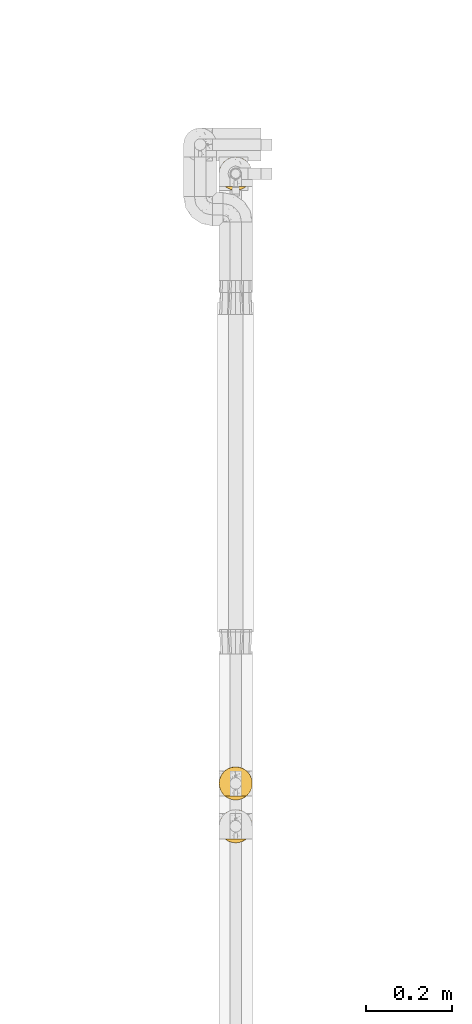
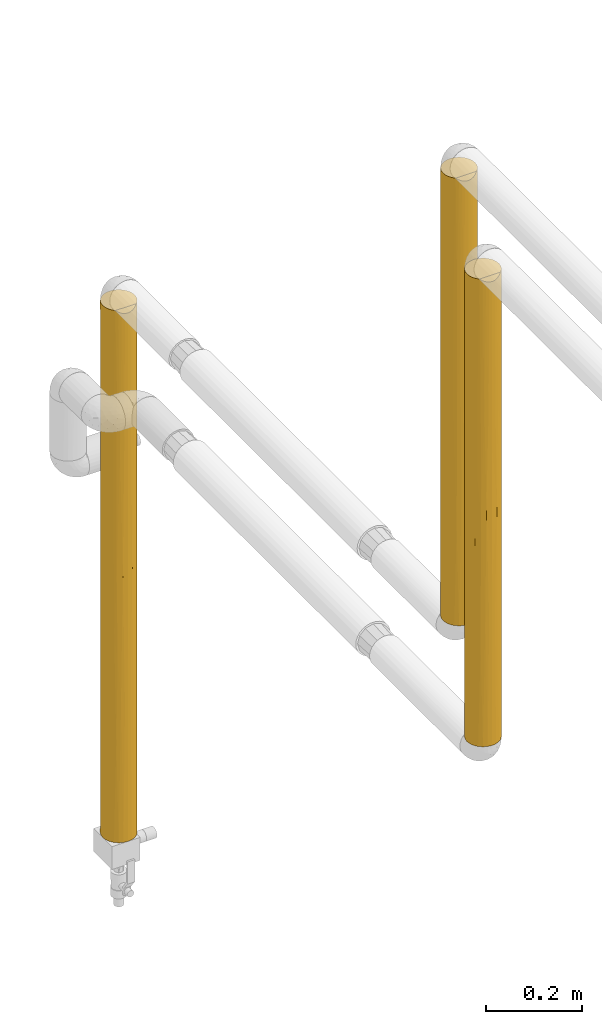
# One storey, part 33 of 827: 3 coverings.
"""IFC2X3 building model written with IfcOpenShell, lengths in millimetres."""

import ifcopenshell
import ifcopenshell.guid

model = None  # the IFC model being written
_history = None  # IfcOwnerHistory: only IFC2X3 demands one
_inside = {}  # id of a spatial element -> (the spatial element, [elements in it])
_under = {}  # id of a project, library or spatial element -> (it, [spatial elements below it])
_declared = {}  # id of a project -> (the project, [libraries it declares])
_typed = {}  # id of a type object -> (the type object, [elements of that type])
_made_of = {}  # id of a material, layer set ... -> (it, [elements and type objects made of it])


def new_model(schema):
    """Start an empty IFC model of exactly this schema.

    Asked for "IFC4X3", IfcOpenShell would pick the latest addendum, in which some entities
    have other attributes; the version numbers below select the first issue.
    IFC2X3 requires an IfcOwnerHistory on every rooted entity: one is made here for all.
    """
    global model, _history
    if schema == "IFC4X3":
        model = ifcopenshell.file(schema_version=(4, 3, 0, 0))
    else:
        model = ifcopenshell.file(schema=schema)
    _inside.clear()
    _under.clear()
    _declared.clear()
    _typed.clear()
    _made_of.clear()
    _history = None
    if model.schema == "IFC2X3":
        org = make("IfcOrganization", Name="unknown")
        user = make(
            "IfcPersonAndOrganization",
            ThePerson=make("IfcPerson", FamilyName="unknown"),
            TheOrganization=org,
        )
        app = make(
            "IfcApplication",
            ApplicationDeveloper=org,
            Version="unknown",
            ApplicationFullName="unknown",
            ApplicationIdentifier="unknown",
        )
        _history = make(
            "IfcOwnerHistory",
            OwningUser=user,
            OwningApplication=app,
            ChangeAction="ADDED",
            CreationDate=0,
        )
    return model


def make(cls, **values):
    """One entity of the class cls with the attributes given. An attribute that is None is left unset."""
    return model.create_entity(
        cls, **{name: value for name, value in values.items() if value is not None}
    )


def entity(cls, *values):
    """Any entity or typed value of the class cls, its attributes in the order of the schema. None: left unset."""
    e = model.create_entity(cls)
    for i, value in enumerate(values):
        if value is not None:
            e[i] = value
    return e


def rooted(cls, **values):
    """An entity with a GlobalId (a new one), such as an element, a storey or a relation."""
    return make(cls, GlobalId=ifcopenshell.guid.new(), OwnerHistory=_history, **values)


def si_unit(unit_type, name, prefix=None):
    """IfcSIUnit, for example si_unit("LENGTHUNIT", "METRE", prefix="MILLI")."""
    return make("IfcSIUnit", UnitType=unit_type, Prefix=prefix, Name=name)


def converted_unit(unit_type, name, factor, base, dimensions=None, offset=None):
    """IfcConversionBasedUnit, such as the inch: factor (a typed value) times the base unit."""
    return make(
        "IfcConversionBasedUnit"
        if offset is None
        else "IfcConversionBasedUnitWithOffset",
        ConversionOffset=offset,
        Dimensions=None
        if dimensions is None
        else entity("IfcDimensionalExponents", *dimensions),
        UnitType=unit_type,
        Name=name,
        ConversionFactor=make(
            "IfcMeasureWithUnit", ValueComponent=factor, UnitComponent=base
        ),
    )


def derived_unit(unit_type, elements):
    """IfcDerivedUnit: a product of units, each with its exponent."""
    return make(
        "IfcDerivedUnit",
        Elements=[
            make("IfcDerivedUnitElement", Unit=unit, Exponent=power)
            for unit, power in elements
        ],
        UnitType=unit_type,
    )


def assignment(units):
    """IfcUnitAssignment: the units of a project."""
    return None if units is None else make("IfcUnitAssignment", Units=units)


def point(xyz):
    """IfcCartesianPoint."""
    return None if xyz is None else make("IfcCartesianPoint", Coordinates=xyz)


def direction(xyz):
    """IfcDirection."""
    return None if xyz is None else make("IfcDirection", DirectionRatios=xyz)


def frame(location, z_axis=None, x_axis=None):
    """IfcAxis2Placement3D, a coordinate frame: its origin and axes. An axis left out is left unset."""
    return make(
        "IfcAxis2Placement3D",
        Location=point(location),
        Axis=direction(z_axis),
        RefDirection=direction(x_axis),
    )


def origin():
    """The frame at (0, 0, 0) with its axes left unset."""
    return frame((0.0, 0.0, 0.0))


def place(relative_to, where):
    """IfcLocalPlacement: puts the frame where relative to a parent placement (None: the world)."""
    return make(
        "IfcLocalPlacement", PlacementRelTo=relative_to, RelativePlacement=where
    )


def context(
    kind, dimensions, precision=None, world=None, true_north=None, identifier=None
):
    """IfcGeometricRepresentationContext, for example the 3D "Model" context."""
    return make(
        "IfcGeometricRepresentationContext",
        ContextIdentifier=identifier,
        ContextType=kind,
        CoordinateSpaceDimension=dimensions,
        Precision=precision,
        WorldCoordinateSystem=world,
        TrueNorth=true_north,
    )


def subcontext(parent, identifier, kind, view, scale=None):
    """IfcGeometricRepresentationSubContext, for example "Body" below "Model"."""
    return make(
        "IfcGeometricRepresentationSubContext",
        ContextIdentifier=identifier,
        ContextType=kind,
        ParentContext=parent,
        TargetScale=scale,
        TargetView=view,
    )


def project(units=None, contexts=None):
    """IfcProject with its units and contexts."""
    return rooted(
        "IfcProject",
        Name="project",
        RepresentationContexts=contexts,
        UnitsInContext=assignment(units),
    )


def spatial(cls, under=None, at=None, **own):
    """A site, building, storey or space (cls), placed at a placement, below another one or the project."""
    s = rooted(cls, ObjectPlacement=at, **own)
    if under is not None:
        _under.setdefault(under.id(), (under, []))[1].append(s)
    return s


def faces_of(points, faces, orient=None, outer=None):
    """IfcFace entities. A face is a list of loops; a loop is a list of indices into points, from 0.

    orient and outer hold one flag for each loop. By default every Orientation is true, the
    first loop of a face is its IfcFaceOuterBound and the others are IfcFaceBound.
    """
    made = []
    for i, loops in enumerate(faces):
        bounds = []
        for j, loop in enumerate(loops):
            is_outer = j == 0 if outer is None else outer[i][j]
            bounds.append(
                make(
                    "IfcFaceOuterBound" if is_outer else "IfcFaceBound",
                    Bound=make("IfcPolyLoop", Polygon=[points[k] for k in loop]),
                    Orientation=True if orient is None else orient[i][j],
                )
            )
        made.append(make("IfcFace", Bounds=bounds))
    return made


def faceted_brep(points, faces, orient=None, outer=None, voids=None):
    """IfcFacetedBrep: a solid bounded by flat faces; with voids (closed shells), ...WithVoids."""
    shared = [point(p) for p in points]
    hull = make("IfcClosedShell", CfsFaces=faces_of(shared, faces, orient, outer))
    if voids is None:
        return make("IfcFacetedBrep", Outer=hull)
    return make(
        "IfcFacetedBrepWithVoids",
        Outer=hull,
        Voids=[
            make(cls, CfsFaces=faces_of(shared, fs, o, b)) for cls, fs, o, b in voids
        ],
    )


def shape(context_of_items, identifier, shape_type, items):
    """IfcShapeRepresentation: the items that make up one representation, for example the "Body"."""
    return make(
        "IfcShapeRepresentation",
        ContextOfItems=context_of_items,
        RepresentationIdentifier=identifier,
        RepresentationType=shape_type,
        Items=items,
    )


def made_of(thing, what):
    """Note that an element or type object is made of a material, layer set ...; save() writes the relation."""
    if what is not None:
        _made_of.setdefault(what.id(), (what, []))[1].append(thing)
    return thing


def element(
    cls,
    number,
    at=None,
    inside=None,
    cuts=None,
    type_object=None,
    material=None,
    context=None,
    identifier="Body",
    shape_type=None,
    held_by="IfcProductDefinitionShape",
    body=None,
    shapes=None,
    **own,
):
    """One element of the class cls, such as IfcWall. Its Tag is "e" and its number.

    at: its placement. inside: the storey or other place that contains it. cuts: it is an
    opening in that element (IfcRelVoidsElement). A single representation is given by context,
    identifier, shape_type and body (its items); several are given by shapes. held_by: the class
    of the entity that holds the representations. save() writes the other relations.
    """
    e = rooted(cls, Tag="e%d" % number, ObjectPlacement=at, **own)
    if body is not None:
        shapes = [shape(context, identifier, shape_type, body)]
    if shapes is not None:
        e.Representation = make(held_by, Representations=shapes)
    if inside is not None:
        _inside.setdefault(inside.id(), (inside, []))[1].append(e)
    if cuts is not None:
        rooted(
            "IfcRelVoidsElement", RelatingBuildingElement=cuts, RelatedOpeningElement=e
        )
    if type_object is not None:
        _typed.setdefault(type_object.id(), (type_object, []))[1].append(e)
    return made_of(e, material)


def aggregate(whole, parts):
    """IfcRelAggregates: a whole, such as a stair, and the parts it consists of."""
    return rooted("IfcRelAggregates", RelatingObject=whole, RelatedObjects=parts)


def save(model, path):
    """Write the relations noted so far, then the file.

    IfcRelAggregates (storeys below a building ...), IfcRelContainedInSpatialStructure (elements
    in a storey), IfcRelDefinesByType, IfcRelAssociatesMaterial and IfcRelDeclares: one each for
    every whole, place, type object, material and project.
    """
    for whole, parts in _under.values():
        aggregate(whole, parts)
    for where, things in _inside.values():
        rooted(
            "IfcRelContainedInSpatialStructure",
            RelatedElements=things,
            RelatingStructure=where,
        )
    for kind, things in _typed.values():
        rooted("IfcRelDefinesByType", RelatedObjects=things, RelatingType=kind)
    for what, things in _made_of.values():
        rooted("IfcRelAssociatesMaterial", RelatedObjects=things, RelatingMaterial=what)
    for by, libraries in _declared.values():
        rooted("IfcRelDeclares", RelatingContext=by, RelatedDefinitions=libraries)
    model.write(path)


model = new_model("IFC2X3")

# Units and contexts
model_context = context("Model", 3, precision=0.01, world=origin(), true_north=direction((6.12303176911189e-17, 1.0)))
body_context = subcontext(model_context, "Body", "Model", "MODEL_VIEW")
ifc_project = project(units=[si_unit("LENGTHUNIT", "METRE", prefix="MILLI"), si_unit("AREAUNIT", "SQUARE_METRE"), si_unit("VOLUMEUNIT", "CUBIC_METRE"), converted_unit("PLANEANGLEUNIT", "DEGREE", entity("IfcRatioMeasure", 0.0174532925199433), si_unit("PLANEANGLEUNIT", "RADIAN"), dimensions=[0, 0, 0, 0, 0, 0, 0]), si_unit("MASSUNIT", "GRAM", prefix="KILO"), derived_unit("MASSDENSITYUNIT", [(si_unit("MASSUNIT", "GRAM", prefix="KILO"), 1), (si_unit("LENGTHUNIT", "METRE"), -3)]), derived_unit("MOMENTOFINERTIAUNIT", [(si_unit("LENGTHUNIT", "METRE"), 4)]), si_unit("TIMEUNIT", "SECOND"), si_unit("FREQUENCYUNIT", "HERTZ"), si_unit("THERMODYNAMICTEMPERATUREUNIT", "DEGREE_CELSIUS"), derived_unit("THERMALTRANSMITTANCEUNIT", [(si_unit("MASSUNIT", "GRAM", prefix="KILO"), 1), (si_unit("THERMODYNAMICTEMPERATUREUNIT", "KELVIN"), -1), (si_unit("TIMEUNIT", "SECOND"), -3)]), derived_unit("VOLUMETRICFLOWRATEUNIT", [(si_unit("LENGTHUNIT", "METRE"), 3), (si_unit("TIMEUNIT", "SECOND"), -1)]), derived_unit("MASSFLOWRATEUNIT", [(si_unit("MASSUNIT", "GRAM", prefix="KILO"), 1), (si_unit("TIMEUNIT", "SECOND"), -1)]), derived_unit("ROTATIONALFREQUENCYUNIT", [(si_unit("TIMEUNIT", "SECOND"), -1)]), si_unit("ELECTRICCURRENTUNIT", "AMPERE"), si_unit("ELECTRICVOLTAGEUNIT", "VOLT"), si_unit("POWERUNIT", "WATT"), si_unit("FORCEUNIT", "NEWTON", prefix="KILO"), si_unit("ILLUMINANCEUNIT", "LUX"), si_unit("LUMINOUSFLUXUNIT", "LUMEN"), si_unit("LUMINOUSINTENSITYUNIT", "CANDELA"), derived_unit("USERDEFINED", [(si_unit("MASSUNIT", "GRAM", prefix="KILO"), -1), (si_unit("LENGTHUNIT", "METRE"), -2), (si_unit("TIMEUNIT", "SECOND"), 3), (si_unit("LUMINOUSFLUXUNIT", "LUMEN"), 1)]), derived_unit("LINEARVELOCITYUNIT", [(si_unit("LENGTHUNIT", "METRE"), 1), (si_unit("TIMEUNIT", "SECOND"), -1)]), si_unit("PRESSUREUNIT", "PASCAL"), derived_unit("USERDEFINED", [(si_unit("LENGTHUNIT", "METRE"), -2), (si_unit("MASSUNIT", "GRAM", prefix="KILO"), 1), (si_unit("TIMEUNIT", "SECOND"), -2)]), derived_unit("LINEARFORCEUNIT", [(si_unit("MASSUNIT", "GRAM", prefix="KILO"), 1), (si_unit("LENGTHUNIT", "METRE"), 1), (si_unit("TIMEUNIT", "SECOND"), -2), (si_unit("LENGTHUNIT", "METRE"), -1)]), derived_unit("PLANARFORCEUNIT", [(si_unit("MASSUNIT", "GRAM", prefix="KILO"), 1), (si_unit("LENGTHUNIT", "METRE"), 1), (si_unit("TIMEUNIT", "SECOND"), -2), (si_unit("LENGTHUNIT", "METRE"), -2)])], contexts=[model_context])

# Site, building, storey
site_placement = place(None, origin())
site = spatial("IfcSite", under=ifc_project, at=site_placement, CompositionType="ELEMENT")
building_placement = place(site_placement, origin())
building = spatial("IfcBuilding", under=site, at=building_placement, CompositionType="ELEMENT")
storey_placement = place(building_placement, frame((0.0, 0.0, 28200.0)))
storey = spatial("IfcBuildingStorey", under=building, at=storey_placement, Name="08", CompositionType="ELEMENT", Elevation=28200.0)

# Coverings
covering_1_placement = place(storey_placement, frame((19736.27, 10367.59, 1832.08)))
element("IfcCovering", 1, at=covering_1_placement, inside=storey, Name=":ADSK_", ObjectType=":ADSK_", PredefinedType="INSULATION", context=body_context, shape_type="Brep", body=[
    faceted_brep([(74.9, 23.98, 1136.14), (77.51, 31.79, 1136.14), (78.4, 40.0, 1136.14), (77.09, 49.93, 1136.14), (73.25, 59.2, 1136.14), (67.15, 67.15, 1136.14), (59.2, 73.25, 1136.14), (49.93, 77.09, 1136.14), (40.0, 78.4, 1136.14), (30.06, 77.09, 1136.14), (20.8, 73.25, 1136.14), (12.84, 67.15, 1136.14), (6.74, 59.2, 1136.14), (2.9, 49.93, 1136.14), (1.6, 40.0, 1136.14), (2.48, 31.79, 1136.14), (5.09, 23.98, 1136.14), (9.31, 16.91, 1136.14), (14.94, 10.9, 1136.14), (65.05, 10.9, 1136.14), (70.68, 16.91, 1136.14), (78.4, 40.0, 1.6), (77.09, 30.06, 1.6), (73.25, 20.8, 1.6), (67.15, 12.84, 1.6), (59.2, 6.74, 1.6), (49.93, 2.9, 1.6), (40.0, 1.6, 1.6), (30.06, 2.9, 1.6), (20.8, 6.74, 1.6), (12.84, 12.84, 1.6), (6.74, 20.8, 1.6), (2.9, 30.06, 1.6), (1.6, 40.0, 1.6), (2.48, 48.2, 1.6), (5.09, 56.01, 1.6), (9.31, 63.08, 1.6), (14.94, 69.1, 1.6), (65.05, 69.1, 1.6), (70.68, 63.08, 1.6), (74.9, 56.01, 1.6), (77.51, 48.2, 1.6), (9.53, 16.62, 266.05), (4.52, 25.3, 349.66), (11.35, 14.42, 810.13), (17.3, 9.02, 565.81), (17.46, 8.9, 858.49), (1.6, 40.0, 434.34), (2.25, 32.94, 326.15), (2.58, 31.33, 568.87), (1.6, 40.0, 217.96), (11.22, 14.57, 572.59), (7.01, 20.33, 690.88), (3.58, 27.82, 865.89), (7.01, 20.33, 929.38), (1.6, 40.0, 703.4), (25.3, 4.52, 327.44), (29.12, 3.17, 560.44), (23.02, 5.55, 705.74), (40.0, 1.6, 910.47), (33.21, 2.2, 1127.44), (29.79, 2.98, 820.25), (26.63, 4.0, 1129.24), (40.0, 1.6, 694.09), (20.48, 6.92, 1132.17), (23.6, 5.27, 919.56), (40.0, 1.6, 1126.84), (40.0, 1.6, 434.34), (32.96, 2.24, 326.15), (40.0, 1.6, 217.97), (16.62, 9.53, 252.83), (1.6, 40.0, 919.78), (50.88, 3.17, 560.44), (68.64, 14.42, 810.13), (68.77, 14.57, 572.59), (72.98, 20.33, 690.88), (54.69, 4.52, 327.44), (63.37, 9.53, 252.83), (70.46, 16.62, 266.05), (47.03, 2.24, 326.15), (50.2, 2.98, 820.25), (53.36, 4.0, 1129.24), (46.78, 2.2, 1127.44), (75.47, 25.3, 349.66), (77.02, 29.82, 560.09), (56.97, 5.55, 705.74), (56.39, 5.27, 919.56), (62.53, 8.9, 858.49), (59.51, 6.92, 1132.17), (78.4, 40.0, 434.34), (77.74, 32.94, 326.15), (78.4, 40.0, 217.97), (78.4, 40.0, 919.77), (76.99, 29.72, 811.58), (78.4, 40.0, 703.39), (62.69, 9.02, 565.81), (72.98, 20.33, 929.38), (72.98, 59.66, 208.35), (76.41, 52.17, 271.85), (77.41, 48.66, 568.87), (72.98, 59.66, 446.86), (75.47, 54.69, 788.07), (59.51, 73.07, 5.57), (62.45, 71.15, 205.97), (68.36, 65.89, 502.0), (68.03, 66.24, 271.86), (70.46, 63.37, 871.68), (77.74, 47.05, 811.58), (56.64, 74.6, 317.56), (53.36, 76.0, 8.5), (46.78, 77.79, 10.29), (40.0, 78.4, 10.9), (40.0, 78.4, 227.27), (63.37, 70.46, 884.9), (47.11, 77.73, 811.58), (40.0, 78.4, 703.39), (40.0, 78.4, 919.77), (50.18, 77.02, 573.52), (48.63, 77.41, 257.08), (40.0, 78.4, 443.64), (54.69, 75.47, 856.69), (71.74, 61.61, 658.7), (62.69, 70.97, 571.93), (56.71, 74.57, 524.54), (11.96, 66.24, 271.86), (17.07, 70.8, 356.88), (33.21, 77.79, 10.29), (25.3, 75.47, 856.69), (9.53, 63.37, 871.68), (16.62, 70.46, 884.9), (20.48, 73.07, 5.57), (23.35, 74.6, 317.56), (26.63, 76.0, 8.5), (31.36, 77.41, 257.08), (23.28, 74.57, 524.54), (7.01, 59.66, 208.35), (4.52, 54.69, 788.07), (17.3, 70.97, 571.93), (3.58, 52.17, 271.85), (7.01, 59.66, 446.86), (29.81, 77.02, 573.52), (2.25, 47.05, 811.58), (2.58, 48.66, 568.87), (8.25, 61.61, 658.7), (32.88, 77.73, 811.58), (11.64, 65.89, 502.0)], [[[0, 1, 2, 3, 4, 5, 6, 7, 8, 9, 10, 11, 12, 13, 14, 15, 16, 17, 18, 19, 20]], [[21, 22, 23, 24, 25, 26, 27, 28, 29, 30, 31, 32, 33, 34, 35, 36, 37, 38, 39, 40, 41]], [[42, 43, 31]], [[44, 45, 46]], [[47, 48, 49]], [[32, 50, 33]], [[43, 42, 51]], [[52, 53, 49]], [[43, 32, 31]], [[50, 48, 47]], [[52, 54, 53]], [[53, 16, 15]], [[49, 53, 55]], [[54, 17, 16]], [[49, 55, 47]], [[54, 44, 17]], [[56, 57, 58]], [[18, 17, 44]], [[59, 60, 61]], [[45, 56, 58]], [[60, 62, 61]], [[63, 61, 57]], [[18, 46, 64]], [[58, 65, 46]], [[66, 60, 59]], [[67, 68, 69]], [[42, 30, 70]], [[30, 42, 31]], [[56, 29, 28]], [[51, 70, 45]], [[65, 64, 46]], [[28, 69, 68]], [[56, 68, 57]], [[52, 49, 43]], [[15, 71, 53]], [[30, 29, 70]], [[51, 45, 44]], [[53, 54, 16]], [[44, 54, 52]], [[44, 52, 51]], [[44, 46, 18]], [[29, 56, 70]], [[45, 70, 56]], [[43, 51, 52]], [[70, 51, 42]], [[28, 27, 69]], [[67, 63, 57]], [[28, 68, 56]], [[57, 68, 67]], [[57, 61, 58]], [[65, 58, 61]], [[46, 45, 58]], [[48, 32, 43]], [[32, 48, 50]], [[49, 48, 43]], [[61, 62, 65]], [[64, 65, 62]], [[61, 63, 59]], [[71, 15, 14]], [[71, 55, 53]], [[63, 67, 72]], [[73, 74, 75]], [[26, 25, 76]], [[77, 24, 78]], [[79, 72, 67]], [[80, 81, 82]], [[75, 83, 84]], [[83, 78, 23]], [[80, 85, 86]], [[25, 24, 77]], [[82, 59, 80]], [[87, 19, 88]], [[19, 87, 73]], [[89, 90, 91]], [[92, 93, 94]], [[84, 94, 93]], [[95, 74, 73]], [[0, 96, 93]], [[24, 23, 78]], [[92, 2, 1]], [[22, 83, 23]], [[72, 85, 80]], [[96, 0, 20]], [[22, 91, 90]], [[79, 26, 76]], [[88, 81, 86]], [[96, 73, 75]], [[0, 93, 1]], [[92, 1, 93]], [[83, 90, 84]], [[85, 72, 76]], [[26, 69, 27]], [[74, 83, 75]], [[77, 95, 76]], [[20, 19, 73]], [[93, 96, 75]], [[20, 73, 96]], [[95, 73, 87]], [[77, 78, 74]], [[76, 25, 77]], [[77, 74, 95]], [[83, 74, 78]], [[26, 79, 69]], [[67, 69, 79]], [[72, 79, 76]], [[85, 76, 95]], [[63, 72, 80]], [[95, 87, 85]], [[86, 85, 87]], [[22, 21, 91]], [[89, 94, 84]], [[22, 90, 83]], [[84, 90, 89]], [[75, 84, 93]], [[88, 86, 87]], [[81, 80, 86]], [[59, 82, 66]], [[59, 63, 80]], [[97, 98, 40]], [[99, 100, 101]], [[101, 4, 3]], [[38, 102, 103]], [[104, 100, 105]], [[105, 39, 38]], [[97, 40, 39]], [[41, 98, 91]], [[40, 98, 41]], [[5, 4, 106]], [[3, 92, 107]], [[99, 107, 94]], [[97, 105, 100]], [[99, 89, 98]], [[108, 102, 109]], [[101, 106, 4]], [[110, 111, 112]], [[6, 5, 113]], [[114, 115, 116]], [[117, 118, 119]], [[119, 115, 117]], [[7, 6, 120]], [[100, 104, 121]], [[110, 112, 118]], [[105, 103, 122]], [[122, 123, 120]], [[94, 107, 92]], [[103, 102, 108]], [[99, 94, 89]], [[109, 110, 118]], [[8, 7, 116]], [[123, 108, 117]], [[117, 108, 118]], [[5, 106, 113]], [[117, 115, 114]], [[21, 41, 91]], [[100, 99, 98]], [[121, 101, 100]], [[113, 122, 120]], [[105, 97, 39]], [[98, 97, 100]], [[122, 113, 106]], [[120, 6, 113]], [[114, 7, 120]], [[7, 114, 116]], [[117, 114, 120]], [[3, 2, 92]], [[99, 101, 107]], [[3, 107, 101]], [[118, 112, 119]], [[109, 118, 108]], [[122, 103, 108]], [[38, 103, 105]], [[105, 122, 104]], [[106, 104, 122]], [[104, 106, 121]], [[101, 121, 106]], [[98, 89, 91]], [[120, 123, 117]], [[122, 108, 123]], [[37, 124, 125]], [[126, 112, 111]], [[127, 10, 9]], [[128, 11, 129]], [[130, 131, 132]], [[37, 125, 130]], [[112, 126, 133]], [[125, 134, 131]], [[36, 124, 37]], [[36, 135, 124]], [[112, 133, 119]], [[136, 13, 12]], [[11, 128, 12]], [[125, 137, 134]], [[138, 35, 34]], [[13, 71, 14]], [[135, 138, 139]], [[140, 115, 119]], [[55, 141, 142]], [[139, 138, 142]], [[133, 132, 131]], [[143, 136, 128]], [[119, 133, 140]], [[142, 138, 47]], [[128, 136, 12]], [[115, 144, 116]], [[140, 144, 115]], [[135, 36, 35]], [[139, 145, 124]], [[71, 141, 55]], [[142, 47, 55]], [[131, 134, 140]], [[137, 128, 129]], [[116, 144, 9]], [[127, 140, 134]], [[139, 142, 136]], [[34, 50, 138]], [[11, 10, 129]], [[128, 137, 145]], [[138, 135, 35]], [[124, 135, 139]], [[10, 127, 129]], [[137, 129, 127]], [[9, 8, 116]], [[140, 127, 144]], [[9, 144, 127]], [[141, 13, 136]], [[13, 141, 71]], [[142, 141, 136]], [[132, 133, 126]], [[140, 133, 131]], [[143, 145, 139]], [[125, 145, 137]], [[136, 143, 139]], [[128, 145, 143]], [[130, 125, 131]], [[145, 125, 124]], [[50, 34, 33]], [[50, 47, 138]], [[127, 134, 137]], [[64, 62, 60, 66, 82, 81, 88, 19, 18]], [[130, 132, 126, 111, 110, 109, 102, 38, 37]]]),
])
covering_2_placement = place(storey_placement, frame((19736.27, 11781.06, 426.5)))
element("IfcCovering", 2, at=covering_2_placement, inside=storey, Name=":ADSK_", ObjectType=":ADSK_", PredefinedType="INSULATION", context=body_context, shape_type="Brep", body=[
    faceted_brep([(77.51, 31.79, 1348.98), (78.4, 40.0, 1348.98), (77.09, 49.93, 1348.98), (73.25, 59.2, 1348.98), (67.15, 67.15, 1348.98), (59.2, 73.25, 1348.98), (49.93, 77.09, 1348.98), (40.0, 78.4, 1348.98), (30.06, 77.09, 1348.98), (20.8, 73.25, 1348.98), (12.84, 67.15, 1348.98), (6.74, 59.2, 1348.98), (2.9, 49.93, 1348.98), (1.6, 40.0, 1348.98), (2.48, 31.79, 1348.98), (5.09, 23.98, 1348.98), (9.31, 16.91, 1348.98), (14.94, 10.9, 1348.98), (65.05, 10.9, 1348.98), (70.68, 16.91, 1348.98), (74.9, 23.98, 1348.98), (73.25, 20.8, 0.0), (67.15, 12.84, 0.0), (59.2, 6.74, 0.0), (49.93, 2.9, 0.0), (40.0, 1.6, 0.0), (30.06, 2.9, 0.0), (20.8, 6.74, 0.0), (12.84, 12.84, 0.0), (6.74, 20.8, 0.0), (2.9, 30.06, 0.0), (1.6, 40.0, 0.0), (2.9, 49.93, 0.0), (6.74, 59.2, 0.0), (12.84, 67.15, 0.0), (20.8, 73.25, 0.0), (30.06, 77.09, 0.0), (40.0, 78.4, 0.0), (49.93, 77.09, 0.0), (59.2, 73.25, 0.0), (67.15, 67.15, 0.0), (73.25, 59.2, 0.0), (77.09, 49.93, 0.0), (78.4, 40.0, 0.0), (77.09, 30.06, 0.0), (53.36, 4.0, 1342.08), (46.78, 2.2, 1340.28), (48.18, 2.48, 1015.12), (70.46, 16.62, 283.44), (63.37, 9.53, 252.76), (46.87, 2.21, 345.28), (54.69, 4.52, 373.39), (67.93, 13.65, 819.56), (72.98, 20.33, 876.9), (68.03, 13.75, 1068.01), (63.19, 9.39, 946.76), (62.48, 8.86, 1158.16), (56.67, 5.4, 983.53), (77.76, 33.04, 349.93), (78.4, 40.0, 216.37), (78.4, 40.0, 483.49), (51.28, 3.29, 692.36), (40.0, 1.6, 1123.3), (40.0, 1.6, 906.93), (76.29, 27.47, 205.68), (59.51, 6.92, 1345.01), (60.98, 7.84, 458.27), (78.4, 40.0, 1132.6), (76.41, 27.82, 1068.02), (72.98, 20.33, 1133.02), (75.47, 25.3, 415.33), (71.23, 17.65, 586.2), (78.4, 40.0, 916.23), (77.11, 30.15, 737.21), (62.75, 9.06, 671.58), (77.82, 33.35, 554.99), (78.4, 40.0, 699.86), (40.0, 1.6, 1339.68), (40.0, 1.6, 690.56), (40.0, 1.6, 474.19), (74.92, 24.03, 628.47), (66.63, 12.33, 513.34), (40.0, 1.6, 216.37), (70.46, 63.37, 259.19), (63.37, 70.46, 324.27), (77.46, 48.4, 700.74), (77.72, 47.17, 1024.42), (75.47, 54.69, 965.07), (54.69, 75.47, 245.05), (77.78, 46.83, 349.93), (75.47, 54.69, 383.91), (40.0, 78.4, 216.37), (40.0, 78.4, 1132.6), (63.37, 70.46, 1071.25), (47.4, 77.67, 921.72), (50.22, 77.01, 1127.26), (54.69, 75.47, 952.15), (65.85, 68.39, 542.23), (54.69, 75.47, 529.72), (62.42, 71.17, 742.23), (47.28, 77.7, 324.56), (51.72, 76.56, 740.93), (46.88, 77.77, 561.65), (57.02, 74.42, 1150.09), (70.46, 63.37, 1096.79), (72.05, 61.15, 885.64), (70.46, 63.37, 674.49), (67.43, 66.87, 844.54), (74.76, 56.3, 705.57), (70.39, 63.46, 466.84), (40.0, 78.4, 432.75), (40.0, 78.4, 649.12), (40.0, 78.4, 699.86), (40.0, 78.4, 865.49), (40.0, 78.4, 916.23), (40.0, 78.4, 483.49), (16.62, 70.46, 259.19), (9.53, 63.37, 324.27), (31.59, 77.46, 700.74), (32.82, 77.72, 1024.42), (25.3, 75.47, 965.07), (4.52, 54.69, 245.05), (33.16, 77.78, 349.93), (25.3, 75.47, 383.91), (1.6, 40.0, 216.37), (1.6, 40.0, 1132.6), (9.53, 63.37, 1071.25), (2.32, 47.4, 921.72), (2.98, 50.22, 1127.26), (4.52, 54.69, 952.15), (11.6, 65.85, 542.23), (4.52, 54.69, 529.72), (8.83, 62.42, 742.23), (2.29, 47.28, 324.56), (3.43, 51.72, 740.93), (2.22, 46.88, 561.65), (5.58, 57.02, 1150.09), (16.62, 70.46, 1096.79), (18.85, 72.05, 885.64), (16.62, 70.46, 674.49), (13.13, 67.43, 844.54), (23.69, 74.76, 705.57), (16.53, 70.39, 466.84), (1.6, 40.0, 432.74), (1.6, 40.0, 649.12), (1.6, 40.0, 699.86), (1.6, 40.0, 865.49), (1.6, 40.0, 916.23), (1.6, 40.0, 483.48), (3.58, 27.82, 1068.02), (12.06, 13.65, 819.56), (11.96, 13.75, 1068.01), (7.01, 20.33, 876.9), (16.8, 9.39, 946.76), (33.12, 2.21, 345.28), (28.71, 3.29, 692.36), (4.52, 25.3, 415.33), (3.7, 27.47, 205.68), (9.53, 16.62, 283.44), (2.23, 33.04, 349.93), (31.81, 2.48, 1015.12), (23.32, 5.4, 983.53), (26.63, 4.0, 1342.08), (20.48, 6.92, 1345.01), (7.01, 20.33, 1133.02), (17.51, 8.86, 1158.16), (19.01, 7.84, 458.27), (17.24, 9.06, 671.58), (33.21, 2.2, 1340.28), (8.77, 17.65, 586.2), (25.3, 4.52, 373.39), (16.62, 9.53, 252.76), (2.17, 33.35, 554.99), (13.36, 12.33, 513.34), (2.88, 30.15, 737.21), (5.39, 23.35, 685.49)], [[[0, 1, 2, 3, 4, 5, 6, 7, 8, 9, 10, 11, 12, 13, 14, 15, 16, 17, 18, 19, 20]], [[21, 22, 23, 24, 25, 26, 27, 28, 29, 30, 31, 32, 33, 34, 35, 36, 37, 38, 39, 40, 41, 42, 43, 44]], [[45, 46, 47]], [[22, 48, 49]], [[50, 24, 51]], [[52, 53, 54]], [[23, 51, 24]], [[55, 56, 57]], [[58, 59, 60]], [[57, 47, 61]], [[21, 48, 22]], [[47, 62, 63]], [[23, 22, 49]], [[64, 48, 21]], [[45, 57, 65]], [[66, 61, 51]], [[62, 47, 46]], [[67, 0, 68]], [[64, 59, 58]], [[20, 68, 0]], [[18, 54, 19]], [[19, 54, 69]], [[70, 71, 48]], [[69, 20, 19]], [[52, 71, 53]], [[64, 44, 59]], [[72, 68, 73]], [[61, 74, 57]], [[56, 18, 65]], [[53, 68, 69]], [[55, 74, 52]], [[73, 75, 76]], [[73, 68, 53]], [[67, 1, 0]], [[46, 77, 62]], [[61, 47, 63]], [[47, 57, 45]], [[78, 79, 61, 63]], [[61, 79, 50]], [[80, 53, 71]], [[70, 58, 75]], [[70, 80, 71]], [[49, 66, 51]], [[52, 81, 71]], [[51, 23, 49]], [[44, 43, 59]], [[82, 50, 79]], [[82, 25, 24]], [[74, 66, 81]], [[24, 50, 82]], [[61, 50, 51]], [[75, 58, 60]], [[58, 70, 64]], [[48, 64, 70]], [[21, 44, 64]], [[76, 72, 73]], [[75, 73, 80]], [[75, 60, 76]], [[55, 52, 54]], [[52, 74, 81]], [[54, 18, 56]], [[74, 55, 57]], [[57, 56, 65]], [[54, 56, 55]], [[53, 69, 54]], [[20, 69, 68]], [[68, 72, 67]], [[49, 48, 81]], [[61, 66, 74]], [[49, 81, 66]], [[48, 71, 81]], [[75, 80, 70]], [[53, 80, 73]], [[83, 40, 84]], [[85, 72, 76, 60]], [[2, 67, 86]], [[2, 87, 3]], [[84, 39, 88]], [[89, 42, 90]], [[38, 37, 91]], [[6, 92, 7]], [[85, 87, 86]], [[5, 4, 93]], [[94, 95, 96]], [[41, 90, 42]], [[97, 98, 99]], [[88, 100, 98]], [[101, 98, 102]], [[72, 86, 67]], [[95, 6, 103]], [[104, 93, 4]], [[39, 38, 88]], [[39, 84, 40]], [[103, 96, 95]], [[96, 93, 99]], [[105, 106, 107]], [[105, 108, 106]], [[42, 59, 43]], [[2, 1, 67]], [[40, 83, 41]], [[98, 100, 102]], [[109, 90, 83]], [[4, 3, 104]], [[105, 107, 104]], [[99, 107, 97]], [[101, 99, 98]], [[84, 97, 109]], [[90, 41, 83]], [[3, 87, 104]], [[105, 104, 87]], [[91, 100, 38]], [[84, 88, 98]], [[100, 91, 110]], [[60, 59, 89]], [[94, 96, 101]], [[100, 110, 102]], [[38, 100, 88]], [[94, 111, 112, 113, 114, 92]], [[102, 111, 101]], [[99, 101, 96]], [[95, 92, 6]], [[92, 95, 94]], [[103, 6, 5]], [[5, 93, 103]], [[93, 96, 103]], [[111, 94, 101]], [[102, 110, 115, 111]], [[85, 86, 72]], [[2, 86, 87]], [[89, 85, 60]], [[90, 109, 108]], [[42, 89, 59]], [[85, 89, 90]], [[109, 97, 106]], [[98, 97, 84]], [[109, 106, 108]], [[84, 109, 83]], [[108, 87, 85]], [[106, 97, 107]], [[87, 108, 105]], [[90, 108, 85]], [[99, 93, 107]], [[104, 107, 93]], [[116, 34, 117]], [[118, 114, 113, 112, 111, 115]], [[8, 92, 119]], [[8, 120, 9]], [[117, 33, 121]], [[122, 36, 123]], [[32, 31, 124]], [[12, 125, 13]], [[118, 120, 119]], [[11, 10, 126]], [[127, 128, 129]], [[35, 123, 36]], [[130, 131, 132]], [[121, 133, 131]], [[134, 131, 135]], [[114, 119, 92]], [[128, 12, 136]], [[137, 126, 10]], [[33, 32, 121]], [[33, 117, 34]], [[136, 129, 128]], [[129, 126, 132]], [[138, 139, 140]], [[138, 141, 139]], [[36, 91, 37]], [[8, 7, 92]], [[34, 116, 35]], [[131, 133, 135]], [[142, 123, 116]], [[10, 9, 137]], [[138, 140, 137]], [[132, 140, 130]], [[134, 132, 131]], [[117, 130, 142]], [[123, 35, 116]], [[9, 120, 137]], [[138, 137, 120]], [[124, 133, 32]], [[117, 121, 131]], [[133, 124, 143]], [[122, 115, 110, 91]], [[127, 129, 134]], [[133, 143, 135]], [[32, 133, 121]], [[127, 144, 145, 146, 147, 125]], [[135, 144, 134]], [[132, 134, 129]], [[128, 125, 12]], [[125, 128, 127]], [[136, 12, 11]], [[11, 126, 136]], [[126, 129, 136]], [[144, 127, 134]], [[135, 143, 148, 144]], [[118, 119, 114]], [[8, 119, 120]], [[122, 118, 115]], [[123, 142, 141]], [[36, 122, 91]], [[118, 122, 123]], [[142, 130, 139]], [[131, 130, 117]], [[142, 139, 141]], [[117, 142, 116]], [[141, 120, 118]], [[139, 130, 140]], [[120, 141, 138]], [[123, 141, 118]], [[132, 126, 140]], [[137, 140, 126]], [[14, 125, 149]], [[150, 151, 152]], [[153, 151, 150]], [[26, 82, 154]], [[155, 79, 78, 63]], [[156, 157, 158]], [[156, 159, 157]], [[157, 159, 124]], [[160, 161, 155]], [[162, 163, 161]], [[31, 30, 124]], [[152, 151, 164]], [[151, 16, 164]], [[165, 163, 17]], [[149, 164, 15]], [[29, 28, 158]], [[166, 155, 167]], [[168, 160, 62]], [[62, 77, 168]], [[169, 156, 158]], [[154, 82, 79]], [[26, 170, 27]], [[153, 165, 151]], [[168, 162, 160]], [[17, 16, 151]], [[158, 28, 171]], [[148, 159, 172]], [[166, 167, 173]], [[174, 152, 149]], [[149, 15, 14]], [[79, 155, 154]], [[174, 149, 147]], [[160, 162, 161]], [[63, 62, 160]], [[161, 167, 155]], [[154, 155, 170]], [[155, 63, 160]], [[174, 145, 172]], [[175, 156, 169]], [[28, 27, 171]], [[169, 152, 175]], [[27, 170, 171]], [[166, 171, 170]], [[26, 25, 82]], [[159, 148, 143, 124]], [[173, 171, 166]], [[169, 173, 150]], [[155, 166, 170]], [[26, 154, 170]], [[157, 124, 30]], [[156, 175, 172]], [[30, 29, 157]], [[158, 157, 29]], [[156, 172, 159]], [[169, 150, 152]], [[174, 147, 146, 145]], [[172, 145, 144, 148]], [[153, 167, 161]], [[167, 153, 150]], [[165, 161, 163]], [[151, 165, 17]], [[161, 165, 153]], [[15, 164, 16]], [[152, 164, 149]], [[125, 14, 13]], [[125, 147, 149]], [[167, 150, 173]], [[169, 158, 173]], [[171, 173, 158]], [[152, 174, 175]], [[175, 174, 172]], [[163, 162, 168, 77, 46, 45, 65, 18, 17]]]),
])
covering_3_placement = place(storey_placement, frame((19736.27, 10268.25, 1585.67)))
element("IfcCovering", 3, at=covering_3_placement, inside=storey, Name=":ADSK_", ObjectType=":ADSK_", PredefinedType="INSULATION", context=body_context, shape_type="Brep", body=[
    faceted_brep([(77.51, 31.79, 1186.96), (78.4, 40.0, 1186.96), (77.09, 49.93, 1186.96), (73.25, 59.2, 1186.96), (67.15, 67.15, 1186.96), (59.2, 73.25, 1186.96), (49.93, 77.09, 1186.96), (40.0, 78.4, 1186.96), (30.06, 77.09, 1186.96), (20.8, 73.25, 1186.96), (12.84, 67.15, 1186.96), (6.74, 59.2, 1186.96), (2.9, 49.93, 1186.96), (1.6, 40.0, 1186.96), (2.48, 31.79, 1186.96), (5.09, 23.98, 1186.96), (9.31, 16.91, 1186.96), (14.94, 10.9, 1186.96), (65.05, 10.9, 1186.96), (70.68, 16.91, 1186.96), (74.9, 23.98, 1186.96), (78.4, 40.0, 1.6), (77.09, 30.06, 1.6), (73.25, 20.8, 1.6), (67.15, 12.84, 1.6), (59.2, 6.74, 1.6), (49.93, 2.9, 1.6), (40.0, 1.6, 1.6), (30.06, 2.9, 1.6), (20.8, 6.74, 1.6), (12.84, 12.84, 1.6), (6.74, 20.8, 1.6), (2.9, 30.06, 1.6), (1.6, 40.0, 1.6), (2.48, 48.2, 1.6), (5.09, 56.01, 1.6), (9.31, 63.08, 1.6), (14.94, 69.1, 1.6), (65.05, 69.1, 1.6), (70.68, 63.08, 1.6), (74.9, 56.01, 1.6), (77.51, 48.2, 1.6), (72.98, 59.66, 211.29), (76.41, 52.17, 274.01), (75.47, 54.69, 816.43), (70.46, 63.37, 916.75), (68.03, 66.24, 274.02), (53.36, 76.0, 8.5), (46.78, 77.79, 10.29), (48.14, 77.52, 335.45), (78.4, 40.0, 217.97), (63.37, 70.46, 935.38), (68.61, 65.6, 551.08), (72.98, 59.66, 452.34), (76.67, 51.37, 554.24), (78.4, 40.0, 970.58), (52.68, 76.24, 578.54), (40.0, 78.4, 754.21), (47.03, 77.74, 862.4), (56.65, 74.6, 329.15), (59.51, 73.07, 5.57), (54.69, 75.47, 850.05), (40.0, 78.4, 227.27), (40.0, 78.4, 443.64), (78.4, 40.0, 754.21), (78.4, 40.0, 434.34), (40.0, 78.4, 970.58), (62.38, 71.2, 209.37), (64.06, 69.92, 401.67), (62.71, 70.96, 597.29), (77.73, 47.11, 862.4), (40.0, 78.4, 10.9), (11.96, 66.24, 274.02), (16.98, 70.73, 377.44), (33.21, 77.79, 10.29), (25.3, 75.47, 850.05), (9.53, 63.37, 916.75), (16.62, 70.46, 935.38), (20.48, 73.07, 5.57), (23.34, 74.6, 329.15), (26.63, 76.0, 8.5), (31.85, 77.52, 335.45), (7.01, 59.66, 452.34), (11.71, 65.97, 507.57), (7.01, 59.66, 211.29), (27.31, 76.24, 578.54), (4.52, 54.69, 816.43), (3.58, 52.17, 274.01), (3.32, 51.37, 554.24), (1.6, 40.0, 970.58), (1.6, 40.0, 754.21), (2.26, 47.11, 862.4), (17.28, 70.96, 597.29), (1.6, 40.0, 434.34), (8.2, 61.53, 684.8), (32.96, 77.74, 862.4), (1.6, 40.0, 217.97), (17.28, 9.03, 591.26), (8.2, 18.46, 503.75), (9.53, 16.62, 271.8), (7.01, 20.33, 736.21), (11.71, 14.02, 680.98), (11.96, 13.75, 914.53), (40.0, 1.6, 217.97), (32.96, 2.25, 326.15), (40.0, 1.6, 744.91), (31.85, 2.47, 853.1), (27.31, 3.75, 610.01), (4.52, 25.3, 372.12), (16.62, 9.53, 253.18), (2.26, 32.88, 326.15), (7.01, 20.33, 977.26), (3.58, 27.82, 914.54), (3.32, 28.62, 634.31), (23.34, 5.39, 859.4), (16.98, 9.26, 811.12), (25.3, 4.52, 338.5), (33.21, 2.2, 1178.26), (26.63, 4.0, 1180.06), (40.0, 1.6, 961.28), (40.0, 1.6, 434.35), (20.48, 6.92, 1182.98), (40.0, 1.6, 1177.66), (54.69, 4.52, 338.5), (52.68, 3.75, 610.01), (62.71, 9.03, 591.26), (56.65, 5.39, 859.4), (48.14, 2.47, 853.1), (77.73, 32.88, 326.15), (75.47, 25.3, 372.12), (77.24, 30.66, 591.08), (53.36, 4.0, 1180.06), (59.51, 6.92, 1182.98), (47.03, 2.25, 326.15), (70.46, 16.62, 271.8), (62.38, 8.79, 979.18), (64.06, 10.07, 786.88), (68.03, 13.75, 914.53), (63.37, 9.53, 253.18), (46.78, 2.2, 1178.26), (72.98, 20.33, 736.21), (76.98, 29.68, 862.4), (72.98, 20.33, 977.26), (68.61, 14.39, 637.48)], [[[0, 1, 2, 3, 4, 5, 6, 7, 8, 9, 10, 11, 12, 13, 14, 15, 16, 17, 18, 19, 20]], [[21, 22, 23, 24, 25, 26, 27, 28, 29, 30, 31, 32, 33, 34, 35, 36, 37, 38, 39, 40, 41]], [[42, 43, 40]], [[3, 44, 45]], [[39, 38, 46]], [[40, 39, 42]], [[47, 48, 49]], [[3, 2, 44]], [[43, 50, 41]], [[4, 3, 45]], [[45, 51, 4]], [[46, 52, 53]], [[53, 54, 43]], [[2, 1, 55]], [[42, 46, 53]], [[56, 57, 58]], [[59, 60, 47]], [[58, 6, 61]], [[56, 59, 49]], [[5, 4, 51]], [[40, 43, 41]], [[62, 63, 49]], [[54, 64, 65]], [[61, 6, 5]], [[6, 66, 7]], [[62, 49, 48]], [[46, 67, 68]], [[56, 69, 59]], [[38, 60, 67]], [[67, 60, 59]], [[46, 68, 52]], [[70, 55, 64]], [[54, 53, 44]], [[54, 65, 43]], [[48, 71, 62]], [[63, 57, 56]], [[49, 59, 47]], [[56, 49, 63]], [[69, 56, 61]], [[52, 44, 53]], [[51, 69, 61]], [[46, 42, 39]], [[43, 42, 53]], [[51, 45, 52]], [[61, 5, 51]], [[54, 44, 70]], [[21, 41, 50]], [[54, 70, 64]], [[55, 70, 2]], [[2, 70, 44]], [[6, 58, 66]], [[57, 66, 58]], [[56, 58, 61]], [[68, 59, 69]], [[38, 67, 46]], [[59, 68, 67]], [[68, 69, 52]], [[51, 52, 69]], [[44, 52, 45]], [[43, 65, 50]], [[37, 72, 73]], [[74, 62, 71]], [[75, 9, 8]], [[76, 10, 77]], [[78, 79, 80]], [[37, 73, 78]], [[80, 81, 74]], [[82, 83, 72]], [[36, 72, 37]], [[36, 84, 72]], [[57, 63, 85]], [[86, 12, 11]], [[82, 87, 88]], [[63, 81, 85]], [[87, 35, 34]], [[12, 89, 13]], [[84, 87, 82]], [[88, 90, 91]], [[75, 85, 92]], [[77, 92, 76]], [[81, 80, 79]], [[11, 76, 86]], [[62, 81, 63]], [[88, 87, 93]], [[92, 94, 76]], [[57, 95, 66]], [[76, 11, 10]], [[84, 36, 35]], [[8, 66, 95]], [[91, 12, 86]], [[79, 73, 92]], [[88, 86, 94]], [[74, 81, 62]], [[85, 81, 79]], [[92, 85, 79]], [[85, 75, 95]], [[10, 9, 77]], [[92, 83, 94]], [[87, 84, 35]], [[72, 84, 82]], [[9, 75, 77]], [[92, 77, 75]], [[34, 96, 87]], [[90, 88, 93]], [[12, 91, 89]], [[90, 89, 91]], [[88, 91, 86]], [[8, 7, 66]], [[85, 95, 57]], [[8, 95, 75]], [[83, 82, 94]], [[73, 83, 92]], [[88, 94, 82]], [[86, 76, 94]], [[78, 73, 79]], [[83, 73, 72]], [[96, 34, 33]], [[96, 93, 87]], [[97, 98, 99]], [[100, 101, 102]], [[17, 16, 102]], [[28, 103, 104]], [[105, 106, 107]], [[99, 108, 31]], [[109, 97, 99]], [[108, 32, 31]], [[110, 32, 108]], [[100, 111, 112]], [[112, 15, 14]], [[113, 112, 90]], [[111, 16, 15]], [[114, 115, 97]], [[16, 111, 102]], [[116, 107, 97]], [[99, 31, 30]], [[117, 118, 106]], [[113, 93, 110]], [[117, 106, 119]], [[105, 107, 120]], [[100, 112, 113]], [[102, 115, 17]], [[118, 121, 114]], [[115, 121, 17]], [[99, 30, 109]], [[119, 122, 117]], [[116, 29, 28]], [[32, 96, 33]], [[120, 104, 103]], [[113, 108, 98]], [[106, 118, 114]], [[105, 119, 106]], [[107, 106, 114]], [[97, 107, 114]], [[107, 116, 104]], [[30, 29, 109]], [[97, 101, 98]], [[112, 111, 15]], [[102, 111, 100]], [[29, 116, 109]], [[97, 109, 116]], [[14, 89, 112]], [[93, 113, 90]], [[32, 110, 96]], [[93, 96, 110]], [[113, 110, 108]], [[28, 27, 103]], [[107, 104, 120]], [[28, 104, 116]], [[101, 100, 98]], [[115, 101, 97]], [[113, 98, 100]], [[108, 99, 98]], [[121, 115, 114]], [[101, 115, 102]], [[89, 14, 13]], [[89, 90, 112]], [[123, 26, 25]], [[124, 125, 126]], [[126, 127, 124]], [[22, 50, 128]], [[129, 128, 130]], [[131, 126, 132]], [[133, 26, 123]], [[105, 127, 119]], [[23, 129, 134]], [[135, 136, 137]], [[25, 24, 138]], [[119, 127, 139]], [[132, 126, 135]], [[19, 18, 137]], [[65, 128, 50]], [[140, 129, 130]], [[130, 64, 141]], [[55, 141, 64]], [[20, 141, 0]], [[24, 23, 134]], [[55, 1, 0]], [[22, 129, 23]], [[124, 120, 133]], [[142, 20, 19]], [[134, 138, 24]], [[131, 139, 127]], [[20, 142, 141]], [[140, 142, 137]], [[137, 143, 140]], [[55, 0, 141]], [[26, 103, 27]], [[18, 132, 135]], [[137, 136, 143]], [[139, 122, 119]], [[105, 120, 124]], [[127, 126, 131]], [[124, 127, 105]], [[125, 124, 123]], [[143, 129, 140]], [[138, 125, 123]], [[137, 142, 19]], [[141, 142, 140]], [[138, 134, 143]], [[123, 25, 138]], [[22, 21, 50]], [[65, 64, 130]], [[22, 128, 129]], [[130, 128, 65]], [[140, 130, 141]], [[26, 133, 103]], [[120, 103, 133]], [[124, 133, 123]], [[136, 126, 125]], [[18, 135, 137]], [[126, 136, 135]], [[136, 125, 143]], [[138, 143, 125]], [[129, 143, 134]], [[121, 118, 117, 122, 139, 131, 132, 18, 17]], [[78, 80, 74, 71, 48, 47, 60, 38, 37]]]),
])

save(model, "model.ifc")
